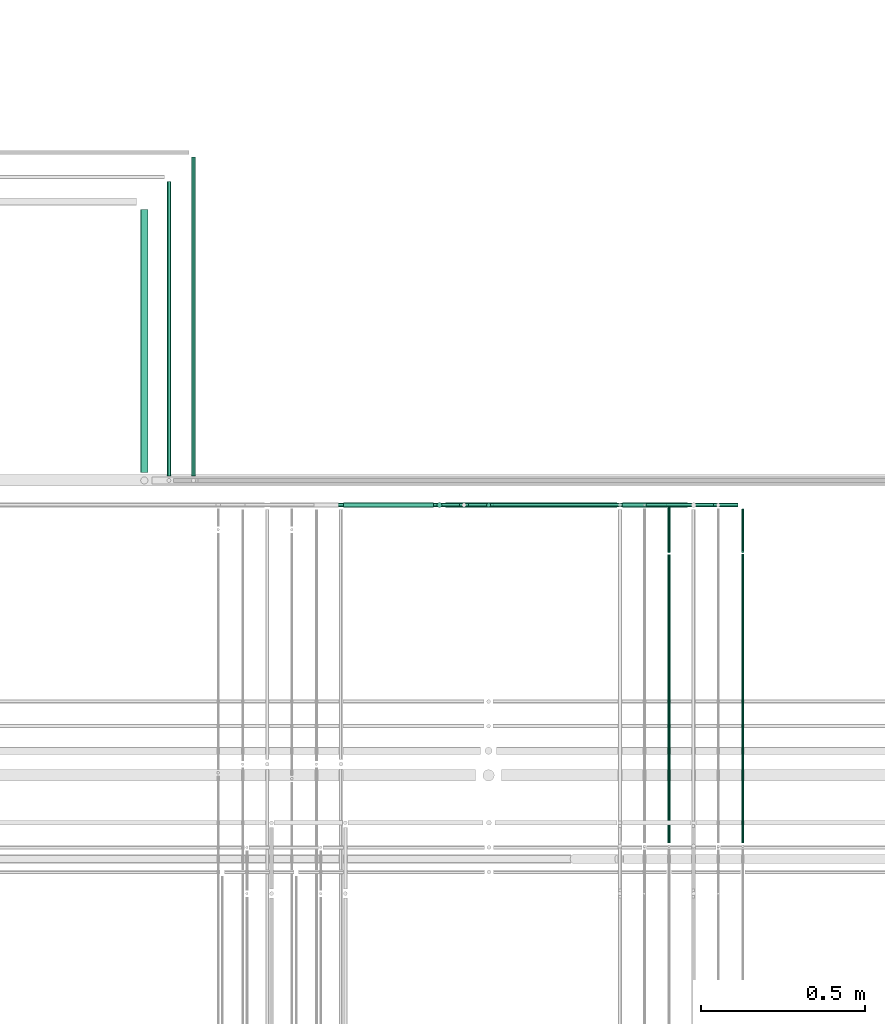
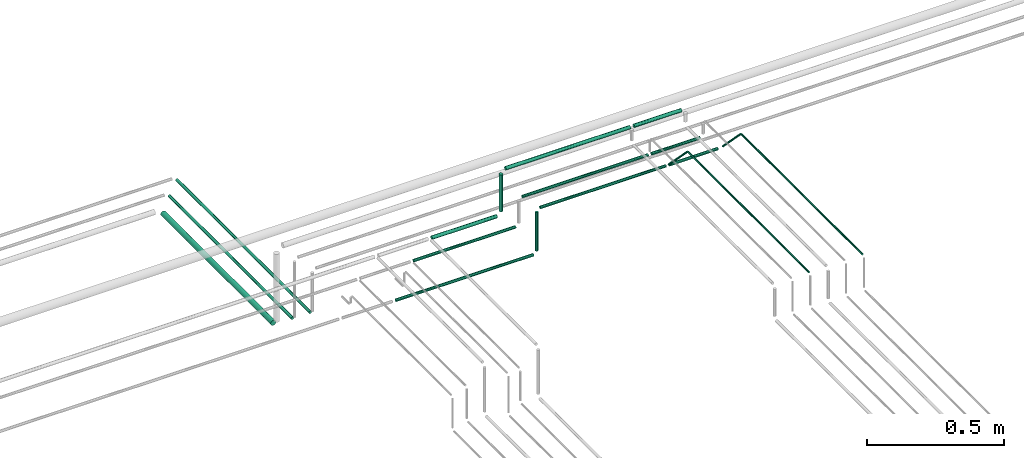
# One storey, part 159 of 331: 18 flow segments.
"""IFC2X3 building model written with IfcOpenShell, lengths in millimetres."""

import ifcopenshell
import ifcopenshell.guid

model = None  # the IFC model being written
_history = None  # IfcOwnerHistory: only IFC2X3 demands one
_inside = {}  # id of a spatial element -> (the spatial element, [elements in it])
_under = {}  # id of a project, library or spatial element -> (it, [spatial elements below it])
_declared = {}  # id of a project -> (the project, [libraries it declares])
_typed = {}  # id of a type object -> (the type object, [elements of that type])
_made_of = {}  # id of a material, layer set ... -> (it, [elements and type objects made of it])


def new_model(schema):
    """Start an empty IFC model of exactly this schema.

    Asked for "IFC4X3", IfcOpenShell would pick the latest addendum, in which some entities
    have other attributes; the version numbers below select the first issue.
    IFC2X3 requires an IfcOwnerHistory on every rooted entity: one is made here for all.
    """
    global model, _history
    if schema == "IFC4X3":
        model = ifcopenshell.file(schema_version=(4, 3, 0, 0))
    else:
        model = ifcopenshell.file(schema=schema)
    _inside.clear()
    _under.clear()
    _declared.clear()
    _typed.clear()
    _made_of.clear()
    _history = None
    if model.schema == "IFC2X3":
        org = make("IfcOrganization", Name="unknown")
        user = make(
            "IfcPersonAndOrganization",
            ThePerson=make("IfcPerson", FamilyName="unknown"),
            TheOrganization=org,
        )
        app = make(
            "IfcApplication",
            ApplicationDeveloper=org,
            Version="unknown",
            ApplicationFullName="unknown",
            ApplicationIdentifier="unknown",
        )
        _history = make(
            "IfcOwnerHistory",
            OwningUser=user,
            OwningApplication=app,
            ChangeAction="ADDED",
            CreationDate=0,
        )
    return model


def make(cls, **values):
    """One entity of the class cls with the attributes given. An attribute that is None is left unset."""
    return model.create_entity(
        cls, **{name: value for name, value in values.items() if value is not None}
    )


def entity(cls, *values):
    """Any entity or typed value of the class cls, its attributes in the order of the schema. None: left unset."""
    e = model.create_entity(cls)
    for i, value in enumerate(values):
        if value is not None:
            e[i] = value
    return e


def rooted(cls, **values):
    """An entity with a GlobalId (a new one), such as an element, a storey or a relation."""
    return make(cls, GlobalId=ifcopenshell.guid.new(), OwnerHistory=_history, **values)


def si_unit(unit_type, name, prefix=None):
    """IfcSIUnit, for example si_unit("LENGTHUNIT", "METRE", prefix="MILLI")."""
    return make("IfcSIUnit", UnitType=unit_type, Prefix=prefix, Name=name)


def converted_unit(unit_type, name, factor, base, dimensions=None, offset=None):
    """IfcConversionBasedUnit, such as the inch: factor (a typed value) times the base unit."""
    return make(
        "IfcConversionBasedUnit"
        if offset is None
        else "IfcConversionBasedUnitWithOffset",
        ConversionOffset=offset,
        Dimensions=None
        if dimensions is None
        else entity("IfcDimensionalExponents", *dimensions),
        UnitType=unit_type,
        Name=name,
        ConversionFactor=make(
            "IfcMeasureWithUnit", ValueComponent=factor, UnitComponent=base
        ),
    )


def derived_unit(unit_type, elements):
    """IfcDerivedUnit: a product of units, each with its exponent."""
    return make(
        "IfcDerivedUnit",
        Elements=[
            make("IfcDerivedUnitElement", Unit=unit, Exponent=power)
            for unit, power in elements
        ],
        UnitType=unit_type,
    )


def assignment(units):
    """IfcUnitAssignment: the units of a project."""
    return None if units is None else make("IfcUnitAssignment", Units=units)


def point(xyz):
    """IfcCartesianPoint."""
    return None if xyz is None else make("IfcCartesianPoint", Coordinates=xyz)


def direction(xyz):
    """IfcDirection."""
    return None if xyz is None else make("IfcDirection", DirectionRatios=xyz)


def frame(location, z_axis=None, x_axis=None):
    """IfcAxis2Placement3D, a coordinate frame: its origin and axes. An axis left out is left unset."""
    return make(
        "IfcAxis2Placement3D",
        Location=point(location),
        Axis=direction(z_axis),
        RefDirection=direction(x_axis),
    )


def frame_2d(location, x_axis=None):
    """IfcAxis2Placement2D, a coordinate frame in the plane: its origin and x axis."""
    return make(
        "IfcAxis2Placement2D", Location=point(location), RefDirection=direction(x_axis)
    )


def origin():
    """The frame at (0, 0, 0) with its axes left unset."""
    return frame((0.0, 0.0, 0.0))


def origin_2d_with_axis():
    """The frame at (0, 0) in the plane with the x axis (1, 0) written out."""
    return frame_2d((0.0, 0.0), x_axis=(1.0, 0.0))


def place(relative_to, where):
    """IfcLocalPlacement: puts the frame where relative to a parent placement (None: the world)."""
    return make(
        "IfcLocalPlacement", PlacementRelTo=relative_to, RelativePlacement=where
    )


def context(
    kind, dimensions, precision=None, world=None, true_north=None, identifier=None
):
    """IfcGeometricRepresentationContext, for example the 3D "Model" context."""
    return make(
        "IfcGeometricRepresentationContext",
        ContextIdentifier=identifier,
        ContextType=kind,
        CoordinateSpaceDimension=dimensions,
        Precision=precision,
        WorldCoordinateSystem=world,
        TrueNorth=true_north,
    )


def subcontext(parent, identifier, kind, view, scale=None):
    """IfcGeometricRepresentationSubContext, for example "Body" below "Model"."""
    return make(
        "IfcGeometricRepresentationSubContext",
        ContextIdentifier=identifier,
        ContextType=kind,
        ParentContext=parent,
        TargetScale=scale,
        TargetView=view,
    )


def project(units=None, contexts=None):
    """IfcProject with its units and contexts."""
    return rooted(
        "IfcProject",
        Name="project",
        RepresentationContexts=contexts,
        UnitsInContext=assignment(units),
    )


def spatial(cls, under=None, at=None, **own):
    """A site, building, storey or space (cls), placed at a placement, below another one or the project."""
    s = rooted(cls, ObjectPlacement=at, **own)
    if under is not None:
        _under.setdefault(under.id(), (under, []))[1].append(s)
    return s


def profile(cls, at=None, kind="AREA", **sizes):
    """A parametric profile (cls). Its sizes go by their IFC names, for example OverallWidth=200.0."""
    return make(cls, ProfileType=kind, Position=at, **sizes)


def circle(**sizes):
    """IfcCircleProfileDef."""
    return profile("IfcCircleProfileDef", **sizes)


def extrude(swept, where, along, depth):
    """IfcExtrudedAreaSolid: the profile swept, set in the frame where, extruded along a direction by depth."""
    return make(
        "IfcExtrudedAreaSolid",
        SweptArea=swept,
        Position=where,
        ExtrudedDirection=direction(along),
        Depth=depth,
    )


def shape(context_of_items, identifier, shape_type, items):
    """IfcShapeRepresentation: the items that make up one representation, for example the "Body"."""
    return make(
        "IfcShapeRepresentation",
        ContextOfItems=context_of_items,
        RepresentationIdentifier=identifier,
        RepresentationType=shape_type,
        Items=items,
    )


def made_of(thing, what):
    """Note that an element or type object is made of a material, layer set ...; save() writes the relation."""
    if what is not None:
        _made_of.setdefault(what.id(), (what, []))[1].append(thing)
    return thing


def type_object(cls, material=None, **own):
    """A type object (cls), such as IfcWallType, which elements share."""
    return made_of(rooted(cls, **own), material)


def element(
    cls,
    number,
    at=None,
    inside=None,
    cuts=None,
    type_object=None,
    material=None,
    context=None,
    identifier="Body",
    shape_type=None,
    held_by="IfcProductDefinitionShape",
    body=None,
    shapes=None,
    **own,
):
    """One element of the class cls, such as IfcWall. Its Tag is "e" and its number.

    at: its placement. inside: the storey or other place that contains it. cuts: it is an
    opening in that element (IfcRelVoidsElement). A single representation is given by context,
    identifier, shape_type and body (its items); several are given by shapes. held_by: the class
    of the entity that holds the representations. save() writes the other relations.
    """
    e = rooted(cls, Tag="e%d" % number, ObjectPlacement=at, **own)
    if body is not None:
        shapes = [shape(context, identifier, shape_type, body)]
    if shapes is not None:
        e.Representation = make(held_by, Representations=shapes)
    if inside is not None:
        _inside.setdefault(inside.id(), (inside, []))[1].append(e)
    if cuts is not None:
        rooted(
            "IfcRelVoidsElement", RelatingBuildingElement=cuts, RelatedOpeningElement=e
        )
    if type_object is not None:
        _typed.setdefault(type_object.id(), (type_object, []))[1].append(e)
    return made_of(e, material)


def aggregate(whole, parts):
    """IfcRelAggregates: a whole, such as a stair, and the parts it consists of."""
    return rooted("IfcRelAggregates", RelatingObject=whole, RelatedObjects=parts)


def save(model, path):
    """Write the relations noted so far, then the file.

    IfcRelAggregates (storeys below a building ...), IfcRelContainedInSpatialStructure (elements
    in a storey), IfcRelDefinesByType, IfcRelAssociatesMaterial and IfcRelDeclares: one each for
    every whole, place, type object, material and project.
    """
    for whole, parts in _under.values():
        aggregate(whole, parts)
    for where, things in _inside.values():
        rooted(
            "IfcRelContainedInSpatialStructure",
            RelatedElements=things,
            RelatingStructure=where,
        )
    for kind, things in _typed.values():
        rooted("IfcRelDefinesByType", RelatedObjects=things, RelatingType=kind)
    for what, things in _made_of.values():
        rooted("IfcRelAssociatesMaterial", RelatedObjects=things, RelatingMaterial=what)
    for by, libraries in _declared.values():
        rooted("IfcRelDeclares", RelatingContext=by, RelatedDefinitions=libraries)
    model.write(path)


model = new_model("IFC2X3")

# Units and contexts
model_context = context("Model", 3, precision=0.01, world=origin(), true_north=direction((6.12303176911189e-17, 1.0)))
body_context = subcontext(model_context, "Body", "Model", "MODEL_VIEW")
ifc_project = project(units=[si_unit("LENGTHUNIT", "METRE", prefix="MILLI"), si_unit("AREAUNIT", "SQUARE_METRE"), si_unit("VOLUMEUNIT", "CUBIC_METRE"), converted_unit("PLANEANGLEUNIT", "DEGREE", entity("IfcRatioMeasure", 0.0174532925199433), si_unit("PLANEANGLEUNIT", "RADIAN"), dimensions=[0, 0, 0, 0, 0, 0, 0]), si_unit("MASSUNIT", "GRAM", prefix="KILO"), derived_unit("MASSDENSITYUNIT", [(si_unit("MASSUNIT", "GRAM", prefix="KILO"), 1), (si_unit("LENGTHUNIT", "METRE"), -3)]), derived_unit("MOMENTOFINERTIAUNIT", [(si_unit("LENGTHUNIT", "METRE"), 4)]), si_unit("TIMEUNIT", "SECOND"), si_unit("FREQUENCYUNIT", "HERTZ"), si_unit("THERMODYNAMICTEMPERATUREUNIT", "DEGREE_CELSIUS"), derived_unit("THERMALTRANSMITTANCEUNIT", [(si_unit("MASSUNIT", "GRAM", prefix="KILO"), 1), (si_unit("THERMODYNAMICTEMPERATUREUNIT", "KELVIN"), -1), (si_unit("TIMEUNIT", "SECOND"), -3)]), derived_unit("VOLUMETRICFLOWRATEUNIT", [(si_unit("LENGTHUNIT", "METRE"), 3), (si_unit("TIMEUNIT", "SECOND"), -1)]), derived_unit("MASSFLOWRATEUNIT", [(si_unit("MASSUNIT", "GRAM", prefix="KILO"), 1), (si_unit("TIMEUNIT", "SECOND"), -1)]), derived_unit("ROTATIONALFREQUENCYUNIT", [(si_unit("TIMEUNIT", "SECOND"), -1)]), si_unit("ELECTRICCURRENTUNIT", "AMPERE"), si_unit("ELECTRICVOLTAGEUNIT", "VOLT"), si_unit("POWERUNIT", "WATT"), si_unit("FORCEUNIT", "NEWTON", prefix="KILO"), si_unit("ILLUMINANCEUNIT", "LUX"), si_unit("LUMINOUSFLUXUNIT", "LUMEN"), si_unit("LUMINOUSINTENSITYUNIT", "CANDELA"), derived_unit("USERDEFINED", [(si_unit("MASSUNIT", "GRAM", prefix="KILO"), -1), (si_unit("LENGTHUNIT", "METRE"), -2), (si_unit("TIMEUNIT", "SECOND"), 3), (si_unit("LUMINOUSFLUXUNIT", "LUMEN"), 1)]), derived_unit("LINEARVELOCITYUNIT", [(si_unit("LENGTHUNIT", "METRE"), 1), (si_unit("TIMEUNIT", "SECOND"), -1)]), si_unit("PRESSUREUNIT", "PASCAL"), derived_unit("USERDEFINED", [(si_unit("LENGTHUNIT", "METRE"), -2), (si_unit("MASSUNIT", "GRAM", prefix="KILO"), 1), (si_unit("TIMEUNIT", "SECOND"), -2)]), derived_unit("LINEARFORCEUNIT", [(si_unit("MASSUNIT", "GRAM", prefix="KILO"), 1), (si_unit("LENGTHUNIT", "METRE"), 1), (si_unit("TIMEUNIT", "SECOND"), -2), (si_unit("LENGTHUNIT", "METRE"), -1)]), derived_unit("PLANARFORCEUNIT", [(si_unit("MASSUNIT", "GRAM", prefix="KILO"), 1), (si_unit("LENGTHUNIT", "METRE"), 1), (si_unit("TIMEUNIT", "SECOND"), -2), (si_unit("LENGTHUNIT", "METRE"), -2)])], contexts=[model_context])

# Site, building, storey
site_placement = place(None, frame((0.0, -0.00077364408347762, 0.0)))
site = spatial("IfcSite", under=ifc_project, at=site_placement, CompositionType="ELEMENT")
building_placement = place(site_placement, origin())
building = spatial("IfcBuilding", under=site, at=building_placement, CompositionType="ELEMENT")
storey_placement = place(building_placement, origin())
storey = spatial("IfcBuildingStorey", under=building, at=storey_placement, CompositionType="ELEMENT", Elevation=0.0)

# Flow segments
pipe_segment_type = type_object("IfcPipeSegmentType", PredefinedType="NOTDEFINED")
flow_segment_1_placement = place(storey_placement, frame((34554.0511495452, 9265.90472776411, 18665.9047277641)))
element("IfcFlowSegment", 1, at=flow_segment_1_placement, inside=storey, type_object=pipe_segment_type, context=body_context, shape_type="SweptSolid", body=[
    extrude(circle(Radius=7.5, at=frame_2d((4.87290208184277e-11, 2.16573425859679e-12), x_axis=(1.0, 0.0))), frame((0.0, 9.09527223596509, 9.09527223591419), z_axis=(1.0, 0.0, 0.0), x_axis=(0.0, 1.0, 0.0)), (0.0, 0.0, 1.0), 274.029401916825),
])
flow_segment_2_placement = place(storey_placement, frame((34935.080551462, 9267.40472776437, 18717.4047277641)))
element("IfcFlowSegment", 2, at=flow_segment_2_placement, inside=storey, type_object=pipe_segment_type, context=body_context, shape_type="SweptSolid", body=[
    extrude(circle(Radius=6.0, at=frame_2d((1.08286712929839e-12, 0.0), x_axis=(1.0, 0.0))), frame((0.0, 7.5952722359167, 7.5952722359167), z_axis=(1.0, 0.0, 0.0), x_axis=(0.0, 1.0, 0.0)), (0.0, 0.0, 1.0), 529.257448914373),
])
flow_segment_3_placement = place(storey_placement, frame((34836.9852792261, 9265.9047277642, 18693.0)))
element("IfcFlowSegment", 3, at=flow_segment_3_placement, inside=storey, type_object=pipe_segment_type, context=body_context, shape_type="SweptSolid", body=[
    extrude(circle(Radius=7.5, at=origin_2d_with_axis()), frame((9.09527223591419, 9.09527223591636, 0.0)), (0.0, 0.0, 1.0), 164.000000000028),
])
flow_segment_4_placement = place(storey_placement, frame((34988.4852792261, 9267.40472776439, 18464.0)))
element("IfcFlowSegment", 4, at=flow_segment_4_placement, inside=storey, type_object=pipe_segment_type, context=body_context, shape_type="SweptSolid", body=[
    extrude(circle(Radius=6.0, at=origin_2d_with_axis()), frame((7.59527223591454, 7.59527223591562, 0.0)), (0.0, 0.0, 1.0), 172.000000000104),
])
flow_segment_5_placement = place(building_placement, frame((33933.4558773093, 9374.0, 18437.4047277641)))
element("IfcFlowSegment", 5, at=flow_segment_5_placement, inside=storey, type_object=pipe_segment_type, context=body_context, shape_type="SweptSolid", body=[
    extrude(circle(Radius=11.0, at=frame_2d((0.0, -2.16573425859679e-12), x_axis=(1.0, 0.0))), frame((12.5952722359177, 0.0, 12.5952722359134), z_axis=(0.0, 1.0, 0.0), x_axis=(1.0, 0.0, 0.0)), (0.0, 0.0, 1.0), 802.025508513981),
])
flow_segment_6_placement = place(building_placement, frame((34013.4558773093, 9364.0, 18442.4047277641)))
element("IfcFlowSegment", 6, at=flow_segment_6_placement, inside=storey, type_object=pipe_segment_type, context=body_context, shape_type="SweptSolid", body=[
    extrude(circle(Radius=6.0, at=frame_2d((0.0, -2.16573425859679e-12), x_axis=(1.0, 0.0))), frame((7.5952722359102, 0.0, 7.59527223591454), z_axis=(0.0, 1.0, 0.0), x_axis=(1.0, 0.0, 0.0)), (0.0, 0.0, 1.0), 897.025508513983),
])
flow_segment_7_placement = place(storey_placement, frame((34088.4558773093, 9364.0, 18442.4047277641)))
element("IfcFlowSegment", 7, at=flow_segment_7_placement, inside=storey, type_object=pipe_segment_type, context=body_context, shape_type="SweptSolid", body=[
    extrude(circle(Radius=6.0, at=frame_2d((0.0, 2.16573425859679e-12), x_axis=(1.0, 0.0))), frame((7.5952722359102, 0.0, 7.59527223591887), z_axis=(0.0, 1.0, 0.0), x_axis=(1.0, 0.0, 0.0)), (0.0, 0.0, 1.0), 972.025508513908),
])
flow_segment_8_placement = place(storey_placement, frame((34864.080551462, 9265.9047277642, 18865.9047277641)))
element("IfcFlowSegment", 8, at=flow_segment_8_placement, inside=storey, type_object=pipe_segment_type, context=body_context, shape_type="SweptSolid", body=[
    extrude(circle(Radius=7.5, at=frame_2d((1.08286712929839e-12, 0.0), x_axis=(1.0, 0.0))), frame((0.0, 9.09527223591636, 9.09527223591636), z_axis=(1.0, 0.0, 0.0), x_axis=(0.0, 1.0, 0.0)), (0.0, 0.0, 1.0), 524.257448914383),
])
flow_segment_9_placement = place(building_placement, frame((35765.7427281405, 9127.38094361078, 18659.9498057376)))
element("IfcFlowSegment", 9, at=flow_segment_9_placement, inside=storey, type_object=pipe_segment_type, context=body_context, shape_type="SweptSolid", body=[
    extrude(circle(Radius=4.0, at=frame_2d((0.0, -1.51028744758326e-12), x_axis=(1.0, 0.0))), frame((5.59527223591499, 4.46217250792673, 137.183293990465), z_axis=(0.0, 0.697355846677976, -0.716725068003097), x_axis=(-1.0, 0.0, 0.0)), (0.0, 0.0, 1.0), 185.285270874972),
])
flow_segment_10_placement = place(storey_placement, frame((35010.080551462, 9267.40472776432, 18642.4047277642)))
element("IfcFlowSegment", 10, at=flow_segment_10_placement, inside=storey, type_object=pipe_segment_type, context=body_context, shape_type="SweptSolid", body=[
    extrude(circle(Radius=6.0, at=frame_2d((-2.4905943973863e-11, -2.16573425859679e-12), x_axis=(1.0, 0.0))), frame((0.0, 7.59527223594161, 7.59527223591887), z_axis=(1.0, 0.0, 0.0), x_axis=(0.0, 1.0, 0.0)), (0.0, 0.0, 1.0), 529.257448914365),
])
flow_segment_11_placement = place(storey_placement, frame((35540.7427281404, 9126.50033180133, 18654.9233628996)))
element("IfcFlowSegment", 11, at=flow_segment_11_placement, inside=storey, type_object=pipe_segment_type, context=body_context, shape_type="SweptSolid", body=[
    extrude(circle(Radius=4.0, at=frame_2d((0.0, 1.51535925176127e-12), x_axis=(1.0, 0.0))), frame((5.59527223591499, 4.45302840906023, 142.218880927327), z_axis=(0.0, 0.699697687168274, -0.714439043285968), x_axis=(-1.0, 0.0, 0.0)), (0.0, 0.0, 1.0), 192.913334227713),
])
flow_segment_12_placement = place(storey_placement, frame((35553.3380003764, 9267.40472776433, 18642.4047277642)))
element("IfcFlowSegment", 12, at=flow_segment_12_placement, inside=storey, type_object=pipe_segment_type, context=body_context, shape_type="SweptSolid", body=[
    extrude(circle(Radius=6.0, at=frame_2d((2.16573425859679e-12, 0.0), x_axis=(1.0, 0.0))), frame((0.0, 7.59527223591995, 7.5952722359167), z_axis=(1.0, 0.0, 0.0), x_axis=(0.0, 1.0, 0.0)), (0.0, 0.0, 1.0), 204.000000000019),
])
flow_segment_13_placement = place(storey_placement, frame((35478.3380003764, 9267.40472776437, 18717.4047277641)))
element("IfcFlowSegment", 13, at=flow_segment_13_placement, inside=storey, type_object=pipe_segment_type, context=body_context, shape_type="SweptSolid", body=[
    extrude(circle(Radius=6.0, at=origin_2d_with_axis()), frame((0.0, 7.59527223591778, 7.5952722359167), z_axis=(1.0, 0.0, 0.0), x_axis=(0.0, 1.0, 0.0)), (0.0, 0.0, 1.0), 203.99999999998),
])
flow_segment_14_placement = place(storey_placement, frame((35404.3380003764, 9265.9047277642, 18865.9047277641)))
element("IfcFlowSegment", 14, at=flow_segment_14_placement, inside=storey, type_object=pipe_segment_type, context=body_context, shape_type="SweptSolid", body=[
    extrude(circle(Radius=7.5, at=frame_2d((-1.08286712929839e-12, 2.16573425859679e-12), x_axis=(1.0, 0.0))), frame((0.0, 9.09527223591744, 9.09527223591419), z_axis=(1.0, 0.0, 0.0), x_axis=(0.0, 1.0, 0.0)), (0.0, 0.0, 1.0), 198.999999999981),
])
flow_segment_15_placement = place(storey_placement, frame((35765.7427281405, 8244.81073448235, 18794.4047277641)))
element("IfcFlowSegment", 15, at=flow_segment_15_placement, inside=storey, type_object=pipe_segment_type, context=body_context, shape_type="SweptSolid", body=[
    extrude(circle(Radius=4.0, at=origin_2d_with_axis()), frame((5.59527223591499, 0.0, 5.59527223591499), z_axis=(0.0, 1.0, 0.0), x_axis=(-1.0, 0.0, 0.0)), (0.0, 0.0, 1.0), 880.24295824964),
])
flow_segment_16_placement = place(storey_placement, frame((35540.7427281404, 8244.81073448236, 18794.4047277641)))
element("IfcFlowSegment", 16, at=flow_segment_16_placement, inside=storey, type_object=pipe_segment_type, context=body_context, shape_type="SweptSolid", body=[
    extrude(circle(Radius=4.0, at=origin_2d_with_axis()), frame((5.59527223591499, 0.0, 5.59527223591499), z_axis=(0.0, 1.0, 0.0), x_axis=(-1.0, 0.0, 0.0)), (0.0, 0.0, 1.0), 879.343834979353),
])
flow_segment_17_placement = place(storey_placement, frame((34403.0511495452, 9267.40472776438, 18442.404727764)))
element("IfcFlowSegment", 17, at=flow_segment_17_placement, inside=storey, type_object=pipe_segment_type, context=body_context, shape_type="SweptSolid", body=[
    extrude(circle(Radius=6.0, at=frame_2d((2.16573425859679e-12, 0.0), x_axis=(1.0, 0.0))), frame((0.0, 7.59527223591995, 7.5952722359167), z_axis=(1.0, 0.0, 0.0), x_axis=(0.0, 1.0, 0.0)), (0.0, 0.0, 1.0), 579.029401916769),
])
flow_segment_18_placement = place(storey_placement, frame((34478.0511495452, 9267.40472776437, 18592.4047277641)))
element("IfcFlowSegment", 18, at=flow_segment_18_placement, inside=storey, type_object=pipe_segment_type, context=body_context, shape_type="SweptSolid", body=[
    extrude(circle(Radius=6.0, at=origin_2d_with_axis()), frame((0.0, 7.59527223591562, 7.5952722359167), z_axis=(1.0, 0.0, 0.0), x_axis=(0.0, 1.0, 0.0)), (0.0, 0.0, 1.0), 429.02940191679),
])

save(model, "model.ifc")
